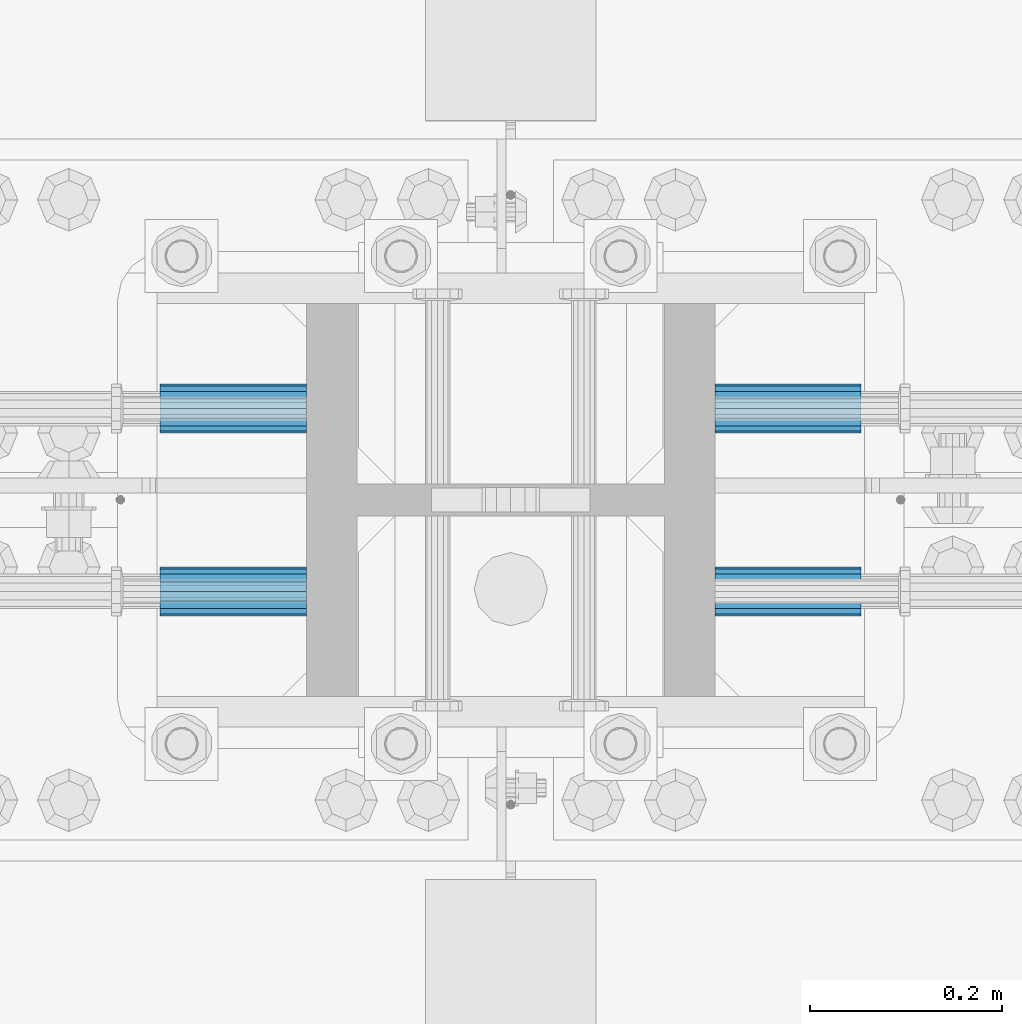
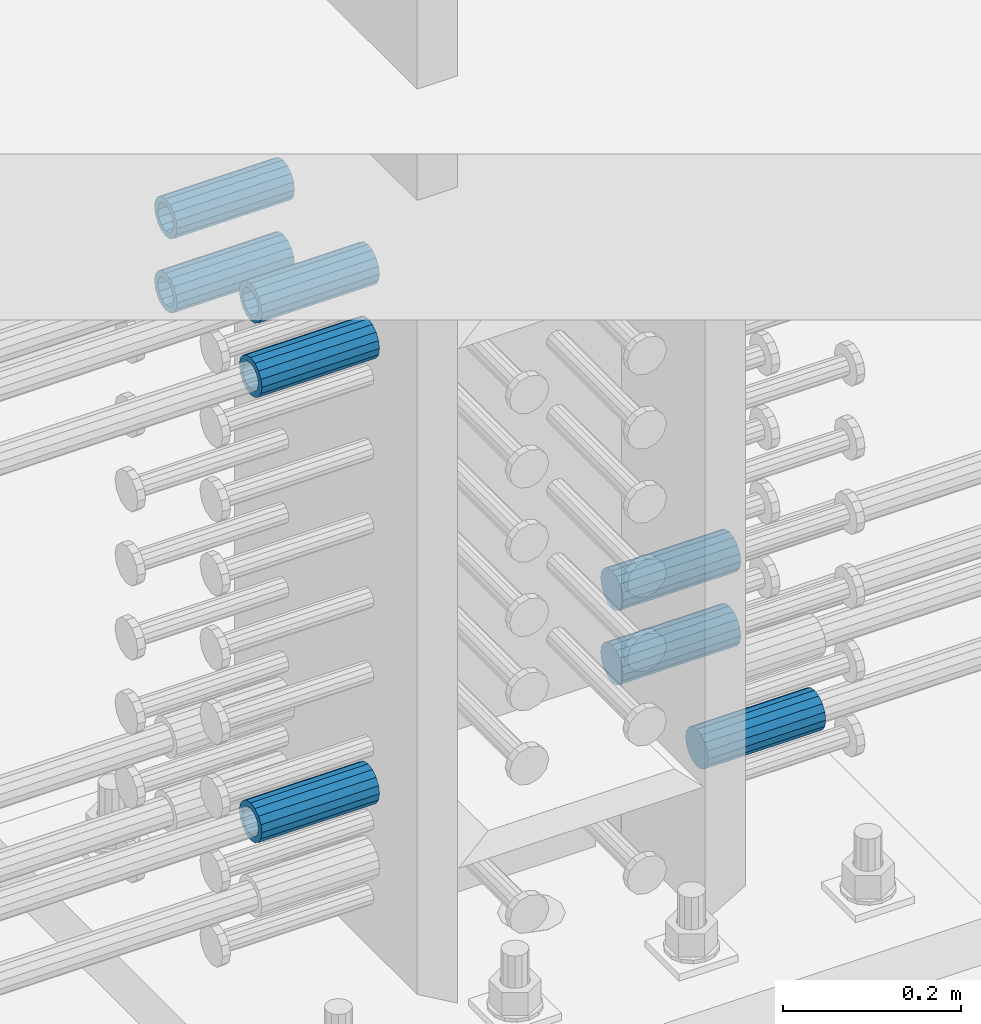
# One storey, part 1214 of 1763: 8 beams, 1 element without a shape of its own.
"""IFC2X3 building model written with IfcOpenShell, lengths in millimetres."""

from ifc_helpers import new_model, si_unit, frame, origin_with_axes, place, context, subcontext, project, spatial, faceted_brep, material, type_object, element, aggregate, save


model = new_model("IFC2X3")

# Units and contexts
model_context = context("Model", 3, precision=1e-05, world=origin_with_axes())
body_context = subcontext(model_context, "Body", "Model", "MODEL_VIEW")
ifc_project = project(units=[si_unit("LENGTHUNIT", "METRE", prefix="MILLI"), si_unit("AREAUNIT", "SQUARE_METRE"), si_unit("VOLUMEUNIT", "CUBIC_METRE"), si_unit("MASSUNIT", "GRAM", prefix="KILO"), si_unit("TIMEUNIT", "SECOND"), si_unit("PLANEANGLEUNIT", "RADIAN"), si_unit("SOLIDANGLEUNIT", "STERADIAN"), si_unit("THERMODYNAMICTEMPERATUREUNIT", "DEGREE_CELSIUS"), si_unit("LUMINOUSINTENSITYUNIT", "LUMEN")], contexts=[model_context])

# Site, building, storey
site_placement = place(None, origin_with_axes())
site = spatial("IfcSite", under=ifc_project, at=site_placement, CompositionType="ELEMENT")
building_placement = place(site_placement, origin_with_axes())
building = spatial("IfcBuilding", under=site, at=building_placement, Name="Undefined", CompositionType="ELEMENT")
storey_placement = place(building_placement, origin_with_axes())
storey = spatial("IfcBuildingStorey", under=building, at=storey_placement, Name="Undefined", CompositionType="ELEMENT", Elevation=0.0)

# Assembly, beams
assembly_placement = place(storey_placement, origin_with_axes())
assembly = element("IfcElementAssembly", 1, at=assembly_placement, inside=storey, Name="COLUMN", AssemblyPlace="NOTDEFINED", PredefinedType="RIGID_FRAME")
ifc_material = material(Name="STEEL/A706-GR.80")
beam_type = type_object("IfcBeamType", PredefinedType="NOTDEFINED")
beam_1_placement = place(assembly_placement, frame((-61807.1622607387, 361.950000000006, 4165.60000000003), z_axis=(0.0, 0.0, 1.0), x_axis=(-1.0, 0.0, 0.0)))
beam_1 = element("IfcBeam", 2, at=beam_1_placement, type_object=beam_type, material=ifc_material, Name="HALF COUPLER F", context=body_context, shape_type="Brep", body=[
    faceted_brep([(32.7659999999996, -8.95349999999962, -15.507916905568), (32.7659999999996, 0.0, -17.9070000000002), (32.7659999999996, 8.95349999999962, -15.507916905568), (32.7659999999996, 15.507916905568, -8.95350000000008), (32.7659999999996, 17.9069999999992, 0.0), (32.7659999999996, 15.507916905568, 8.95350000000008), (32.7659999999996, 8.95349999999962, 15.507916905568), (32.7659999999996, 0.0, 17.9070000000002), (32.7659999999996, -8.95349999999962, 15.507916905568), (32.7659999999996, -15.507916905568, 8.95350000000008), (32.7659999999996, -17.9069999999992, 0.0), (32.7659999999996, -15.507916905568, -8.95350000000008), (152.400103102711, -15.507916905568, 8.95350000000008), (152.400103102711, -8.95349999999962, 15.507916905568), (152.400103102711, -17.9069999999992, 0.0), (152.400103102711, -15.507916905568, -8.95350000000008), (152.400103102711, -8.95349999999962, -15.507916905568), (152.400103102711, 0.0, -17.9070000000002), (152.400103102711, 8.95349999999962, -15.507916905568), (152.400103102711, 15.507916905568, -8.95350000000008), (152.400103102711, 17.9069999999992, 0.0), (152.400103102711, 15.507916905568, 8.95350000000008), (152.400103102711, 8.95349999999962, 15.507916905568), (152.400103102711, 0.0, 17.9070000000002), (0.0, -23.466540125788, 9.72015918207308), (0.0, -17.9605122421381, 17.9605122421385), (0.0, -9.72015918207398, 23.4665401257867), (0.0, 0.0, 25.4000000000001), (0.0, 9.72015918207398, 23.4665401257867), (0.0, 17.9605122421381, 17.9605122421385), (0.0, 23.466540125788, 9.72015918207308), (0.0, 25.4000000000015, 0.0), (0.0, 23.466540125788, -9.72015918207308), (0.0, 17.9605122421381, -17.9605122421385), (0.0, 9.72015918207398, -23.4665401257867), (0.0, 0.0, -25.4000000000001), (0.0, -9.72015918207398, -23.4665401257867), (0.0, -17.9605122421381, -17.9605122421385), (0.0, -23.466540125788, -9.72015918207308), (0.0, -25.4000000000015, 0.0), (152.400103102711, -25.4000000000015, 0.0), (152.400103102711, -23.466540125788, 9.72015918207308), (152.400103102711, -17.9605122421381, 17.9605122421385), (152.400103102711, -9.72015918207398, 23.4665401257867), (152.400103102711, 0.0, 25.4000000000001), (152.400103102711, 9.72015918207398, 23.4665401257867), (152.400103102711, 17.9605122421381, 17.9605122421385), (152.400103102711, 23.466540125788, 9.72015918207308), (152.400103102711, 25.4000000000015, 0.0), (152.400103102711, 23.466540125788, -9.72015918207308), (152.400103102711, 17.9605122421381, -17.9605122421385), (152.400103102711, 9.72015918207398, -23.4665401257867), (152.400103102711, 0.0, -25.4000000000001), (152.400103102711, -9.72015918207398, -23.4665401257867), (152.400103102711, -17.9605122421381, -17.9605122421385), (152.400103102711, -23.466540125788, -9.72015918207308)], [[[0, 1, 2, 3, 4, 5, 6, 7, 8, 9, 10, 11]], [[12, 9, 8, 13]], [[14, 10, 9, 12]], [[15, 11, 10, 14]], [[16, 0, 11, 15]], [[17, 1, 0, 16]], [[18, 2, 1, 17]], [[19, 3, 2, 18]], [[20, 4, 3, 19]], [[21, 5, 4, 20]], [[22, 6, 5, 21]], [[23, 7, 6, 22]], [[13, 8, 7, 23]], [[24, 25, 26, 27, 28, 29, 30, 31, 32, 33, 34, 35, 36, 37, 38, 39]], [[24, 39, 40, 41]], [[25, 24, 41, 42]], [[26, 25, 42, 43]], [[27, 26, 43, 44]], [[28, 27, 44, 45]], [[29, 28, 45, 46]], [[30, 29, 46, 47]], [[31, 30, 47, 48]], [[32, 31, 48, 49]], [[33, 32, 49, 50]], [[34, 33, 50, 51]], [[35, 34, 51, 52]], [[36, 35, 52, 53]], [[37, 36, 53, 54]], [[38, 37, 54, 55]], [[39, 38, 55, 40]], [[54, 53, 52, 51, 50, 49, 48, 47, 46, 45, 44, 43, 42, 41, 40, 55], [21, 20, 19, 18, 17, 16, 15, 14, 12, 13, 23, 22]]]),
])
beam_2_placement = place(assembly_placement, frame((-61807.162260665, 552.449999999419, 4775.20000000009), z_axis=(0.0, 0.0, 1.0), x_axis=(-1.0, 0.0, 0.0)))
beam_2 = element("IfcBeam", 3, at=beam_2_placement, type_object=beam_type, material=ifc_material, Name="HALF COUPLER F", context=body_context, shape_type="Brep", body=[
    faceted_brep([(0.0, -23.466540125788, 9.72015918207308), (0.0, -17.9605122421381, 17.9605122421385), (0.0, -9.72015918207398, 23.4665401257867), (0.0, 0.0, 25.4000000000001), (0.0, 9.72015918207398, 23.4665401257867), (0.0, 17.9605122421381, 17.9605122421385), (0.0, 23.466540125788, 9.72015918207308), (0.0, 25.4000000000015, 0.0), (0.0, 23.466540125788, -9.72015918207308), (0.0, 17.9605122421381, -17.9605122421385), (0.0, 9.72015918207398, -23.4665401257867), (0.0, 0.0, -25.4000000000001), (0.0, -9.72015918207398, -23.4665401257867), (0.0, -17.9605122421381, -17.9605122421385), (0.0, -23.466540125788, -9.72015918207308), (0.0, -25.4000000000015, 0.0), (152.400103102711, -25.4000000000015, 0.0), (152.400103102711, -23.466540125788, 9.72015918207308), (152.400103102711, -17.9605122421381, 17.9605122421385), (152.400103102711, -9.72015918207398, 23.4665401257867), (152.400103102711, 0.0, 25.4000000000001), (152.400103102711, 9.72015918207398, 23.4665401257867), (152.400103102711, 17.9605122421381, 17.9605122421385), (152.400103102711, 23.466540125788, 9.72015918207308), (152.400103102711, 25.4000000000015, 0.0), (152.400103102711, 23.466540125788, -9.72015918207308), (152.400103102711, 17.9605122421381, -17.9605122421385), (152.400103102711, 9.72015918207398, -23.4665401257867), (152.400103102711, 0.0, -25.4000000000001), (152.400103102711, -9.72015918207398, -23.4665401257867), (152.400103102711, -17.9605122421381, -17.9605122421385), (152.400103102711, -23.466540125788, -9.72015918207308), (152.400103102711, 15.507916905568, 8.95350000000008), (152.400103102711, 17.9069999999992, 0.0), (152.400103102711, 15.507916905568, -8.95350000000008), (152.400103102711, 8.95349999999962, -15.507916905568), (152.400103102711, 0.0, -17.9070000000002), (152.400103102711, -8.95349999999962, -15.507916905568), (152.400103102711, -15.507916905568, -8.95350000000008), (152.400103102711, -17.9069999999992, 0.0), (152.400103102711, -15.507916905568, 8.95350000000008), (152.400103102711, -8.95349999999962, 15.507916905568), (152.400103102711, 0.0, 17.9070000000002), (152.400103102711, 8.95349999999962, 15.507916905568), (32.7659999999996, -8.95349999999962, -15.507916905568), (32.7659999999996, -15.507916905568, -8.95350000000008), (32.7659999999996, 0.0, -17.9070000000002), (32.7659999999996, 8.95349999999962, -15.507916905568), (32.7659999999996, 15.507916905568, -8.95350000000008), (32.7659999999996, 17.9069999999992, 0.0), (32.7659999999996, 15.507916905568, 8.95350000000008), (32.7659999999996, 8.95349999999962, 15.507916905568), (32.7659999999996, 0.0, 17.9070000000002), (32.7659999999996, -8.95349999999962, 15.507916905568), (32.7659999999996, -15.507916905568, 8.95350000000008), (32.7659999999996, -17.9069999999992, 0.0)], [[[0, 1, 2, 3, 4, 5, 6, 7, 8, 9, 10, 11, 12, 13, 14, 15]], [[0, 15, 16, 17]], [[1, 0, 17, 18]], [[2, 1, 18, 19]], [[3, 2, 19, 20]], [[4, 3, 20, 21]], [[5, 4, 21, 22]], [[6, 5, 22, 23]], [[7, 6, 23, 24]], [[8, 7, 24, 25]], [[9, 8, 25, 26]], [[10, 9, 26, 27]], [[11, 10, 27, 28]], [[12, 11, 28, 29]], [[13, 12, 29, 30]], [[14, 13, 30, 31]], [[15, 14, 31, 16]], [[30, 29, 28, 27, 26, 25, 24, 23, 22, 21, 20, 19, 18, 17, 16, 31], [32, 33, 34, 35, 36, 37, 38, 39, 40, 41, 42, 43]], [[37, 44, 45, 38]], [[36, 46, 44, 37]], [[35, 47, 46, 36]], [[34, 48, 47, 35]], [[33, 49, 48, 34]], [[32, 50, 49, 33]], [[43, 51, 50, 32]], [[42, 52, 51, 43]], [[41, 53, 52, 42]], [[40, 54, 53, 41]], [[39, 55, 54, 40]], [[38, 45, 55, 39]], [[44, 46, 47, 48, 49, 50, 51, 52, 53, 54, 55, 45]]]),
])
beam_3_placement = place(assembly_placement, frame((-61807.1621920032, 361.950000000006, 4775.20000000009), z_axis=(0.0, 0.0, 1.0), x_axis=(-1.0, 0.0, 0.0)))
beam_3 = element("IfcBeam", 4, at=beam_3_placement, type_object=beam_type, material=ifc_material, Name="HALF COUPLER F", context=body_context, shape_type="Brep", body=[
    faceted_brep([(32.7659999999996, -8.95349999999962, -15.507916905568), (32.7659999999996, 0.0, -17.9070000000002), (32.7659999999996, 8.95349999999962, -15.507916905568), (32.7659999999996, 15.507916905568, -8.95350000000008), (32.7659999999996, 17.9069999999992, 0.0), (32.7659999999996, 15.507916905568, 8.95350000000008), (32.7659999999996, 8.95349999999962, 15.507916905568), (32.7659999999996, 0.0, 17.9070000000002), (32.7659999999996, -8.95349999999962, 15.507916905568), (32.7659999999996, -15.507916905568, 8.95350000000008), (32.7659999999996, -17.9069999999992, 0.0), (32.7659999999996, -15.507916905568, -8.95350000000008), (152.400103102711, -15.507916905568, 8.95350000000008), (152.400103102711, -8.95349999999962, 15.507916905568), (152.400103102711, -17.9069999999992, 0.0), (152.400103102711, -15.507916905568, -8.95350000000008), (152.400103102711, -8.95349999999962, -15.507916905568), (152.400103102711, 0.0, -17.9070000000002), (152.400103102711, 8.95349999999962, -15.507916905568), (152.400103102711, 15.507916905568, -8.95350000000008), (152.400103102711, 17.9069999999992, 0.0), (152.400103102711, 15.507916905568, 8.95350000000008), (152.400103102711, 8.95349999999962, 15.507916905568), (152.400103102711, 0.0, 17.9070000000002), (0.0, -23.466540125788, 9.72015918207308), (0.0, -17.9605122421381, 17.9605122421385), (0.0, -9.72015918207398, 23.4665401257867), (0.0, 0.0, 25.4000000000001), (0.0, 9.72015918207398, 23.4665401257867), (0.0, 17.9605122421381, 17.9605122421385), (0.0, 23.466540125788, 9.72015918207308), (0.0, 25.4000000000015, 0.0), (0.0, 23.466540125788, -9.72015918207308), (0.0, 17.9605122421381, -17.9605122421385), (0.0, 9.72015918207398, -23.4665401257867), (0.0, 0.0, -25.4000000000001), (0.0, -9.72015918207398, -23.4665401257867), (0.0, -17.9605122421381, -17.9605122421385), (0.0, -23.466540125788, -9.72015918207308), (0.0, -25.4000000000015, 0.0), (152.400103102711, -25.4000000000015, 0.0), (152.400103102711, -23.466540125788, 9.72015918207308), (152.400103102711, -17.9605122421381, 17.9605122421385), (152.400103102711, -9.72015918207398, 23.4665401257867), (152.400103102711, 0.0, 25.4000000000001), (152.400103102711, 9.72015918207398, 23.4665401257867), (152.400103102711, 17.9605122421381, 17.9605122421385), (152.400103102711, 23.466540125788, 9.72015918207308), (152.400103102711, 25.4000000000015, 0.0), (152.400103102711, 23.466540125788, -9.72015918207308), (152.400103102711, 17.9605122421381, -17.9605122421385), (152.400103102711, 9.72015918207398, -23.4665401257867), (152.400103102711, 0.0, -25.4000000000001), (152.400103102711, -9.72015918207398, -23.4665401257867), (152.400103102711, -17.9605122421381, -17.9605122421385), (152.400103102711, -23.466540125788, -9.72015918207308)], [[[0, 1, 2, 3, 4, 5, 6, 7, 8, 9, 10, 11]], [[12, 9, 8, 13]], [[14, 10, 9, 12]], [[15, 11, 10, 14]], [[16, 0, 11, 15]], [[17, 1, 0, 16]], [[18, 2, 1, 17]], [[19, 3, 2, 18]], [[20, 4, 3, 19]], [[21, 5, 4, 20]], [[22, 6, 5, 21]], [[23, 7, 6, 22]], [[13, 8, 7, 23]], [[24, 25, 26, 27, 28, 29, 30, 31, 32, 33, 34, 35, 36, 37, 38, 39]], [[24, 39, 40, 41]], [[25, 24, 41, 42]], [[26, 25, 42, 43]], [[27, 26, 43, 44]], [[28, 27, 44, 45]], [[29, 28, 45, 46]], [[30, 29, 46, 47]], [[31, 30, 47, 48]], [[32, 31, 48, 49]], [[33, 32, 49, 50]], [[34, 33, 50, 51]], [[35, 34, 51, 52]], [[36, 35, 52, 53]], [[37, 36, 53, 54]], [[38, 37, 54, 55]], [[39, 38, 55, 40]], [[54, 53, 52, 51, 50, 49, 48, 47, 46, 45, 44, 43, 42, 41, 40, 55], [21, 20, 19, 18, 17, 16, 15, 14, 12, 13, 23, 22]]]),
])
beam_4_placement = place(assembly_placement, frame((-61807.162260665, 552.449999999419, 4876.80000000009), z_axis=(0.0, 0.0, 1.0), x_axis=(-1.0, 0.0, 0.0)))
beam_4 = element("IfcBeam", 5, at=beam_4_placement, type_object=beam_type, material=ifc_material, Name="HALF COUPLER F", context=body_context, shape_type="Brep", body=[
    faceted_brep([(0.0, -23.466540125788, 9.72015918207308), (0.0, -17.9605122421381, 17.9605122421385), (0.0, -9.72015918207398, 23.4665401257867), (0.0, 0.0, 25.4000000000001), (0.0, 9.72015918207398, 23.4665401257867), (0.0, 17.9605122421381, 17.9605122421385), (0.0, 23.466540125788, 9.72015918207308), (0.0, 25.4000000000015, 0.0), (0.0, 23.466540125788, -9.72015918207308), (0.0, 17.9605122421381, -17.9605122421385), (0.0, 9.72015918207398, -23.4665401257867), (0.0, 0.0, -25.4000000000001), (0.0, -9.72015918207398, -23.4665401257867), (0.0, -17.9605122421381, -17.9605122421385), (0.0, -23.466540125788, -9.72015918207308), (0.0, -25.4000000000015, 0.0), (152.400103102711, -25.4000000000015, 0.0), (152.400103102711, -23.466540125788, 9.72015918207308), (152.400103102711, -17.9605122421381, 17.9605122421385), (152.400103102711, -9.72015918207398, 23.4665401257867), (152.400103102711, 0.0, 25.4000000000001), (152.400103102711, 9.72015918207398, 23.4665401257867), (152.400103102711, 17.9605122421381, 17.9605122421385), (152.400103102711, 23.466540125788, 9.72015918207308), (152.400103102711, 25.4000000000015, 0.0), (152.400103102711, 23.466540125788, -9.72015918207308), (152.400103102711, 17.9605122421381, -17.9605122421385), (152.400103102711, 9.72015918207398, -23.4665401257867), (152.400103102711, 0.0, -25.4000000000001), (152.400103102711, -9.72015918207398, -23.4665401257867), (152.400103102711, -17.9605122421381, -17.9605122421385), (152.400103102711, -23.466540125788, -9.72015918207308), (152.400103102711, 15.507916905568, 8.95350000000008), (152.400103102711, 17.9069999999992, 0.0), (152.400103102711, 15.507916905568, -8.95350000000008), (152.400103102711, 8.95349999999962, -15.507916905568), (152.400103102711, 0.0, -17.9070000000002), (152.400103102711, -8.95349999999962, -15.507916905568), (152.400103102711, -15.507916905568, -8.95350000000008), (152.400103102711, -17.9069999999992, 0.0), (152.400103102711, -15.507916905568, 8.95350000000008), (152.400103102711, -8.95349999999962, 15.507916905568), (152.400103102711, 0.0, 17.9070000000002), (152.400103102711, 8.95349999999962, 15.507916905568), (32.7659999999996, -8.95349999999962, -15.507916905568), (32.7659999999996, -15.507916905568, -8.95350000000008), (32.7659999999996, 0.0, -17.9070000000002), (32.7659999999996, 8.95349999999962, -15.507916905568), (32.7659999999996, 15.507916905568, -8.95350000000008), (32.7659999999996, 17.9069999999992, 0.0), (32.7659999999996, 15.507916905568, 8.95350000000008), (32.7659999999996, 8.95349999999962, 15.507916905568), (32.7659999999996, 0.0, 17.9070000000002), (32.7659999999996, -8.95349999999962, 15.507916905568), (32.7659999999996, -15.507916905568, 8.95350000000008), (32.7659999999996, -17.9069999999992, 0.0)], [[[0, 1, 2, 3, 4, 5, 6, 7, 8, 9, 10, 11, 12, 13, 14, 15]], [[0, 15, 16, 17]], [[1, 0, 17, 18]], [[2, 1, 18, 19]], [[3, 2, 19, 20]], [[4, 3, 20, 21]], [[5, 4, 21, 22]], [[6, 5, 22, 23]], [[7, 6, 23, 24]], [[8, 7, 24, 25]], [[9, 8, 25, 26]], [[10, 9, 26, 27]], [[11, 10, 27, 28]], [[12, 11, 28, 29]], [[13, 12, 29, 30]], [[14, 13, 30, 31]], [[15, 14, 31, 16]], [[30, 29, 28, 27, 26, 25, 24, 23, 22, 21, 20, 19, 18, 17, 16, 31], [32, 33, 34, 35, 36, 37, 38, 39, 40, 41, 42, 43]], [[37, 44, 45, 38]], [[36, 46, 44, 37]], [[35, 47, 46, 36]], [[34, 48, 47, 35]], [[33, 49, 48, 34]], [[32, 50, 49, 33]], [[43, 51, 50, 32]], [[42, 52, 51, 43]], [[41, 53, 52, 42]], [[40, 54, 53, 41]], [[39, 55, 54, 40]], [[38, 45, 55, 39]], [[44, 46, 47, 48, 49, 50, 51, 52, 53, 54, 55, 45]]]),
])
beam_5_placement = place(assembly_placement, frame((-61807.1621920032, 361.950000000006, 4876.80000000009), z_axis=(0.0, 0.0, 1.0), x_axis=(-1.0, 0.0, 0.0)))
beam_5 = element("IfcBeam", 6, at=beam_5_placement, type_object=beam_type, material=ifc_material, Name="HALF COUPLER F", context=body_context, shape_type="Brep", body=[
    faceted_brep([(32.7659999999996, -8.95349999999962, -15.507916905568), (32.7659999999996, 0.0, -17.9070000000002), (32.7659999999996, 8.95349999999962, -15.507916905568), (32.7659999999996, 15.507916905568, -8.95350000000008), (32.7659999999996, 17.9069999999992, 0.0), (32.7659999999996, 15.507916905568, 8.95350000000008), (32.7659999999996, 8.95349999999962, 15.507916905568), (32.7659999999996, 0.0, 17.9070000000002), (32.7659999999996, -8.95349999999962, 15.507916905568), (32.7659999999996, -15.507916905568, 8.95350000000008), (32.7659999999996, -17.9069999999992, 0.0), (32.7659999999996, -15.507916905568, -8.95350000000008), (152.400103102711, -15.507916905568, 8.95350000000008), (152.400103102711, -8.95349999999962, 15.507916905568), (152.400103102711, -17.9069999999992, 0.0), (152.400103102711, -15.507916905568, -8.95350000000008), (152.400103102711, -8.95349999999962, -15.507916905568), (152.400103102711, 0.0, -17.9070000000002), (152.400103102711, 8.95349999999962, -15.507916905568), (152.400103102711, 15.507916905568, -8.95350000000008), (152.400103102711, 17.9069999999992, 0.0), (152.400103102711, 15.507916905568, 8.95350000000008), (152.400103102711, 8.95349999999962, 15.507916905568), (152.400103102711, 0.0, 17.9070000000002), (0.0, -23.466540125788, 9.72015918207308), (0.0, -17.9605122421381, 17.9605122421385), (0.0, -9.72015918207398, 23.4665401257867), (0.0, 0.0, 25.4000000000001), (0.0, 9.72015918207398, 23.4665401257867), (0.0, 17.9605122421381, 17.9605122421385), (0.0, 23.466540125788, 9.72015918207308), (0.0, 25.4000000000015, 0.0), (0.0, 23.466540125788, -9.72015918207308), (0.0, 17.9605122421381, -17.9605122421385), (0.0, 9.72015918207398, -23.4665401257867), (0.0, 0.0, -25.4000000000001), (0.0, -9.72015918207398, -23.4665401257867), (0.0, -17.9605122421381, -17.9605122421385), (0.0, -23.466540125788, -9.72015918207308), (0.0, -25.4000000000015, 0.0), (152.400103102711, -25.4000000000015, 0.0), (152.400103102711, -23.466540125788, 9.72015918207308), (152.400103102711, -17.9605122421381, 17.9605122421385), (152.400103102711, -9.72015918207398, 23.4665401257867), (152.400103102711, 0.0, 25.4000000000001), (152.400103102711, 9.72015918207398, 23.4665401257867), (152.400103102711, 17.9605122421381, 17.9605122421385), (152.400103102711, 23.466540125788, 9.72015918207308), (152.400103102711, 25.4000000000015, 0.0), (152.400103102711, 23.466540125788, -9.72015918207308), (152.400103102711, 17.9605122421381, -17.9605122421385), (152.400103102711, 9.72015918207398, -23.4665401257867), (152.400103102711, 0.0, -25.4000000000001), (152.400103102711, -9.72015918207398, -23.4665401257867), (152.400103102711, -17.9605122421381, -17.9605122421385), (152.400103102711, -23.466540125788, -9.72015918207308)], [[[0, 1, 2, 3, 4, 5, 6, 7, 8, 9, 10, 11]], [[12, 9, 8, 13]], [[14, 10, 9, 12]], [[15, 11, 10, 14]], [[16, 0, 11, 15]], [[17, 1, 0, 16]], [[18, 2, 1, 17]], [[19, 3, 2, 18]], [[20, 4, 3, 19]], [[21, 5, 4, 20]], [[22, 6, 5, 21]], [[23, 7, 6, 22]], [[13, 8, 7, 23]], [[24, 25, 26, 27, 28, 29, 30, 31, 32, 33, 34, 35, 36, 37, 38, 39]], [[24, 39, 40, 41]], [[25, 24, 41, 42]], [[26, 25, 42, 43]], [[27, 26, 43, 44]], [[28, 27, 44, 45]], [[29, 28, 45, 46]], [[30, 29, 46, 47]], [[31, 30, 47, 48]], [[32, 31, 48, 49]], [[33, 32, 49, 50]], [[34, 33, 50, 51]], [[35, 34, 51, 52]], [[36, 35, 52, 53]], [[37, 36, 53, 54]], [[38, 37, 54, 55]], [[39, 38, 55, 40]], [[54, 53, 52, 51, 50, 49, 48, 47, 46, 45, 44, 43, 42, 41, 40, 55], [21, 20, 19, 18, 17, 16, 15, 14, 12, 13, 23, 22]]]),
])
beam_6_placement = place(assembly_placement, frame((-61381.7122179961, 552.449999999419, 4064.0), z_axis=(0.0, 0.0, 1.0), x_axis=(1.0, 0.0, 0.0)))
beam_6 = element("IfcBeam", 7, at=beam_6_placement, type_object=beam_type, material=ifc_material, Name="HALF COUPLER F", context=body_context, shape_type="Brep", body=[
    faceted_brep([(0.0, -23.466540125788, 9.72015918207308), (0.0, -17.9605122421381, 17.9605122421385), (0.0, -9.72015918207398, 23.4665401257867), (0.0, 0.0, 25.4000000000001), (0.0, 9.72015918207398, 23.4665401257867), (0.0, 17.9605122421381, 17.9605122421385), (0.0, 23.466540125788, 9.72015918207308), (0.0, 25.4000000000015, 0.0), (0.0, 23.466540125788, -9.72015918207308), (0.0, 17.9605122421381, -17.9605122421385), (0.0, 9.72015918207398, -23.4665401257867), (0.0, 0.0, -25.4000000000001), (0.0, -9.72015918207398, -23.4665401257867), (0.0, -17.9605122421381, -17.9605122421385), (0.0, -23.466540125788, -9.72015918207308), (0.0, -25.4000000000015, 0.0), (152.400103102711, -25.4000000000015, 0.0), (152.400103102711, -23.466540125788, 9.72015918207308), (152.400103102711, -17.9605122421381, 17.9605122421385), (152.400103102711, -9.72015918207398, 23.4665401257867), (152.400103102711, 0.0, 25.4000000000001), (152.400103102711, 9.72015918207398, 23.4665401257867), (152.400103102711, 17.9605122421381, 17.9605122421385), (152.400103102711, 23.466540125788, 9.72015918207308), (152.400103102711, 25.4000000000015, 0.0), (152.400103102711, 23.466540125788, -9.72015918207308), (152.400103102711, 17.9605122421381, -17.9605122421385), (152.400103102711, 9.72015918207398, -23.4665401257867), (152.400103102711, 0.0, -25.4000000000001), (152.400103102711, -9.72015918207398, -23.4665401257867), (152.400103102711, -17.9605122421381, -17.9605122421385), (152.400103102711, -23.466540125788, -9.72015918207308), (152.400103102711, 15.507916905568, 8.95350000000008), (152.400103102711, 17.9069999999992, 0.0), (152.400103102711, 15.507916905568, -8.95350000000008), (152.400103102711, 8.95349999999962, -15.507916905568), (152.400103102711, 0.0, -17.9070000000002), (152.400103102711, -8.95349999999962, -15.507916905568), (152.400103102711, -15.507916905568, -8.95350000000008), (152.400103102711, -17.9069999999992, 0.0), (152.400103102711, -15.507916905568, 8.95350000000008), (152.400103102711, -8.95349999999962, 15.507916905568), (152.400103102711, 0.0, 17.9070000000002), (152.400103102711, 8.95349999999962, 15.507916905568), (32.7659999999996, -8.95349999999962, -15.507916905568), (32.7659999999996, -15.507916905568, -8.95350000000008), (32.7659999999996, 0.0, -17.9070000000002), (32.7659999999996, 8.95349999999962, -15.507916905568), (32.7659999999996, 15.507916905568, -8.95350000000008), (32.7659999999996, 17.9069999999992, 0.0), (32.7659999999996, 15.507916905568, 8.95350000000008), (32.7659999999996, 8.95349999999962, 15.507916905568), (32.7659999999996, 0.0, 17.9070000000002), (32.7659999999996, -8.95349999999962, 15.507916905568), (32.7659999999996, -15.507916905568, 8.95350000000008), (32.7659999999996, -17.9069999999992, 0.0)], [[[0, 1, 2, 3, 4, 5, 6, 7, 8, 9, 10, 11, 12, 13, 14, 15]], [[0, 15, 16, 17]], [[1, 0, 17, 18]], [[2, 1, 18, 19]], [[3, 2, 19, 20]], [[4, 3, 20, 21]], [[5, 4, 21, 22]], [[6, 5, 22, 23]], [[7, 6, 23, 24]], [[8, 7, 24, 25]], [[9, 8, 25, 26]], [[10, 9, 26, 27]], [[11, 10, 27, 28]], [[12, 11, 28, 29]], [[13, 12, 29, 30]], [[14, 13, 30, 31]], [[15, 14, 31, 16]], [[30, 29, 28, 27, 26, 25, 24, 23, 22, 21, 20, 19, 18, 17, 16, 31], [32, 33, 34, 35, 36, 37, 38, 39, 40, 41, 42, 43]], [[37, 44, 45, 38]], [[36, 46, 44, 37]], [[35, 47, 46, 36]], [[34, 48, 47, 35]], [[33, 49, 48, 34]], [[32, 50, 49, 33]], [[43, 51, 50, 32]], [[42, 52, 51, 43]], [[41, 53, 52, 42]], [[40, 54, 53, 41]], [[39, 55, 54, 40]], [[38, 45, 55, 39]], [[44, 46, 47, 48, 49, 50, 51, 52, 53, 54, 55, 45]]]),
])
beam_7_placement = place(assembly_placement, frame((-61381.7122866579, 361.950000000006, 4064.0), z_axis=(0.0, 0.0, 1.0), x_axis=(1.0, 0.0, 0.0)))
beam_7 = element("IfcBeam", 8, at=beam_7_placement, type_object=beam_type, material=ifc_material, Name="HALF COUPLER F", context=body_context, shape_type="Brep", body=[
    faceted_brep([(32.7659999999996, -8.95349999999962, -15.507916905568), (32.7659999999996, 0.0, -17.9070000000002), (32.7659999999996, 8.95349999999962, -15.507916905568), (32.7659999999996, 15.507916905568, -8.95350000000008), (32.7659999999996, 17.9069999999992, 0.0), (32.7659999999996, 15.507916905568, 8.95350000000008), (32.7659999999996, 8.95349999999962, 15.507916905568), (32.7659999999996, 0.0, 17.9070000000002), (32.7659999999996, -8.95349999999962, 15.507916905568), (32.7659999999996, -15.507916905568, 8.95350000000008), (32.7659999999996, -17.9069999999992, 0.0), (32.7659999999996, -15.507916905568, -8.95350000000008), (152.400103102711, -15.507916905568, 8.95350000000008), (152.400103102711, -8.95349999999962, 15.507916905568), (152.400103102711, -17.9069999999992, 0.0), (152.400103102711, -15.507916905568, -8.95350000000008), (152.400103102711, -8.95349999999962, -15.507916905568), (152.400103102711, 0.0, -17.9070000000002), (152.400103102711, 8.95349999999962, -15.507916905568), (152.400103102711, 15.507916905568, -8.95350000000008), (152.400103102711, 17.9069999999992, 0.0), (152.400103102711, 15.507916905568, 8.95350000000008), (152.400103102711, 8.95349999999962, 15.507916905568), (152.400103102711, 0.0, 17.9070000000002), (0.0, -23.466540125788, 9.72015918207308), (0.0, -17.9605122421381, 17.9605122421385), (0.0, -9.72015918207398, 23.4665401257867), (0.0, 0.0, 25.4000000000001), (0.0, 9.72015918207398, 23.4665401257867), (0.0, 17.9605122421381, 17.9605122421385), (0.0, 23.466540125788, 9.72015918207308), (0.0, 25.4000000000015, 0.0), (0.0, 23.466540125788, -9.72015918207308), (0.0, 17.9605122421381, -17.9605122421385), (0.0, 9.72015918207398, -23.4665401257867), (0.0, 0.0, -25.4000000000001), (0.0, -9.72015918207398, -23.4665401257867), (0.0, -17.9605122421381, -17.9605122421385), (0.0, -23.466540125788, -9.72015918207308), (0.0, -25.4000000000015, 0.0), (152.400103102711, -25.4000000000015, 0.0), (152.400103102711, -23.466540125788, 9.72015918207308), (152.400103102711, -17.9605122421381, 17.9605122421385), (152.400103102711, -9.72015918207398, 23.4665401257867), (152.400103102711, 0.0, 25.4000000000001), (152.400103102711, 9.72015918207398, 23.4665401257867), (152.400103102711, 17.9605122421381, 17.9605122421385), (152.400103102711, 23.466540125788, 9.72015918207308), (152.400103102711, 25.4000000000015, 0.0), (152.400103102711, 23.466540125788, -9.72015918207308), (152.400103102711, 17.9605122421381, -17.9605122421385), (152.400103102711, 9.72015918207398, -23.4665401257867), (152.400103102711, 0.0, -25.4000000000001), (152.400103102711, -9.72015918207398, -23.4665401257867), (152.400103102711, -17.9605122421381, -17.9605122421385), (152.400103102711, -23.466540125788, -9.72015918207308)], [[[0, 1, 2, 3, 4, 5, 6, 7, 8, 9, 10, 11]], [[12, 9, 8, 13]], [[14, 10, 9, 12]], [[15, 11, 10, 14]], [[16, 0, 11, 15]], [[17, 1, 0, 16]], [[18, 2, 1, 17]], [[19, 3, 2, 18]], [[20, 4, 3, 19]], [[21, 5, 4, 20]], [[22, 6, 5, 21]], [[23, 7, 6, 22]], [[13, 8, 7, 23]], [[24, 25, 26, 27, 28, 29, 30, 31, 32, 33, 34, 35, 36, 37, 38, 39]], [[24, 39, 40, 41]], [[25, 24, 41, 42]], [[26, 25, 42, 43]], [[27, 26, 43, 44]], [[28, 27, 44, 45]], [[29, 28, 45, 46]], [[30, 29, 46, 47]], [[31, 30, 47, 48]], [[32, 31, 48, 49]], [[33, 32, 49, 50]], [[34, 33, 50, 51]], [[35, 34, 51, 52]], [[36, 35, 52, 53]], [[37, 36, 53, 54]], [[38, 37, 54, 55]], [[39, 38, 55, 40]], [[54, 53, 52, 51, 50, 49, 48, 47, 46, 45, 44, 43, 42, 41, 40, 55], [21, 20, 19, 18, 17, 16, 15, 14, 12, 13, 23, 22]]]),
])
beam_8_placement = place(assembly_placement, frame((-61381.7122179962, 552.449999999419, 4165.60000000003), z_axis=(0.0, 0.0, 1.0), x_axis=(1.0, 0.0, 0.0)))
beam_8 = element("IfcBeam", 9, at=beam_8_placement, type_object=beam_type, material=ifc_material, Name="HALF COUPLER F", context=body_context, shape_type="Brep", body=[
    faceted_brep([(0.0, -23.466540125788, 9.72015918207308), (0.0, -17.9605122421381, 17.9605122421385), (0.0, -9.72015918207398, 23.4665401257867), (0.0, 0.0, 25.4000000000001), (0.0, 9.72015918207398, 23.4665401257867), (0.0, 17.9605122421381, 17.9605122421385), (0.0, 23.466540125788, 9.72015918207308), (0.0, 25.4000000000015, 0.0), (0.0, 23.466540125788, -9.72015918207308), (0.0, 17.9605122421381, -17.9605122421385), (0.0, 9.72015918207398, -23.4665401257867), (0.0, 0.0, -25.4000000000001), (0.0, -9.72015918207398, -23.4665401257867), (0.0, -17.9605122421381, -17.9605122421385), (0.0, -23.466540125788, -9.72015918207308), (0.0, -25.4000000000015, 0.0), (152.400103102711, -25.4000000000015, 0.0), (152.400103102711, -23.466540125788, 9.72015918207308), (152.400103102711, -17.9605122421381, 17.9605122421385), (152.400103102711, -9.72015918207398, 23.4665401257867), (152.400103102711, 0.0, 25.4000000000001), (152.400103102711, 9.72015918207398, 23.4665401257867), (152.400103102711, 17.9605122421381, 17.9605122421385), (152.400103102711, 23.466540125788, 9.72015918207308), (152.400103102711, 25.4000000000015, 0.0), (152.400103102711, 23.466540125788, -9.72015918207308), (152.400103102711, 17.9605122421381, -17.9605122421385), (152.400103102711, 9.72015918207398, -23.4665401257867), (152.400103102711, 0.0, -25.4000000000001), (152.400103102711, -9.72015918207398, -23.4665401257867), (152.400103102711, -17.9605122421381, -17.9605122421385), (152.400103102711, -23.466540125788, -9.72015918207308), (152.400103102711, 15.507916905568, 8.95350000000008), (152.400103102711, 17.9069999999992, 0.0), (152.400103102711, 15.507916905568, -8.95350000000008), (152.400103102711, 8.95349999999962, -15.507916905568), (152.400103102711, 0.0, -17.9070000000002), (152.400103102711, -8.95349999999962, -15.507916905568), (152.400103102711, -15.507916905568, -8.95350000000008), (152.400103102711, -17.9069999999992, 0.0), (152.400103102711, -15.507916905568, 8.95350000000008), (152.400103102711, -8.95349999999962, 15.507916905568), (152.400103102711, 0.0, 17.9070000000002), (152.400103102711, 8.95349999999962, 15.507916905568), (32.7659999999996, -8.95349999999962, -15.507916905568), (32.7659999999996, -15.507916905568, -8.95350000000008), (32.7659999999996, 0.0, -17.9070000000002), (32.7659999999996, 8.95349999999962, -15.507916905568), (32.7659999999996, 15.507916905568, -8.95350000000008), (32.7659999999996, 17.9069999999992, 0.0), (32.7659999999996, 15.507916905568, 8.95350000000008), (32.7659999999996, 8.95349999999962, 15.507916905568), (32.7659999999996, 0.0, 17.9070000000002), (32.7659999999996, -8.95349999999962, 15.507916905568), (32.7659999999996, -15.507916905568, 8.95350000000008), (32.7659999999996, -17.9069999999992, 0.0)], [[[0, 1, 2, 3, 4, 5, 6, 7, 8, 9, 10, 11, 12, 13, 14, 15]], [[0, 15, 16, 17]], [[1, 0, 17, 18]], [[2, 1, 18, 19]], [[3, 2, 19, 20]], [[4, 3, 20, 21]], [[5, 4, 21, 22]], [[6, 5, 22, 23]], [[7, 6, 23, 24]], [[8, 7, 24, 25]], [[9, 8, 25, 26]], [[10, 9, 26, 27]], [[11, 10, 27, 28]], [[12, 11, 28, 29]], [[13, 12, 29, 30]], [[14, 13, 30, 31]], [[15, 14, 31, 16]], [[30, 29, 28, 27, 26, 25, 24, 23, 22, 21, 20, 19, 18, 17, 16, 31], [32, 33, 34, 35, 36, 37, 38, 39, 40, 41, 42, 43]], [[37, 44, 45, 38]], [[36, 46, 44, 37]], [[35, 47, 46, 36]], [[34, 48, 47, 35]], [[33, 49, 48, 34]], [[32, 50, 49, 33]], [[43, 51, 50, 32]], [[42, 52, 51, 43]], [[41, 53, 52, 42]], [[40, 54, 53, 41]], [[39, 55, 54, 40]], [[38, 45, 55, 39]], [[44, 46, 47, 48, 49, 50, 51, 52, 53, 54, 55, 45]]]),
])
aggregate(assembly, [beam_1, beam_2, beam_3, beam_4, beam_5, beam_6, beam_7, beam_8])

save(model, "model.ifc")
